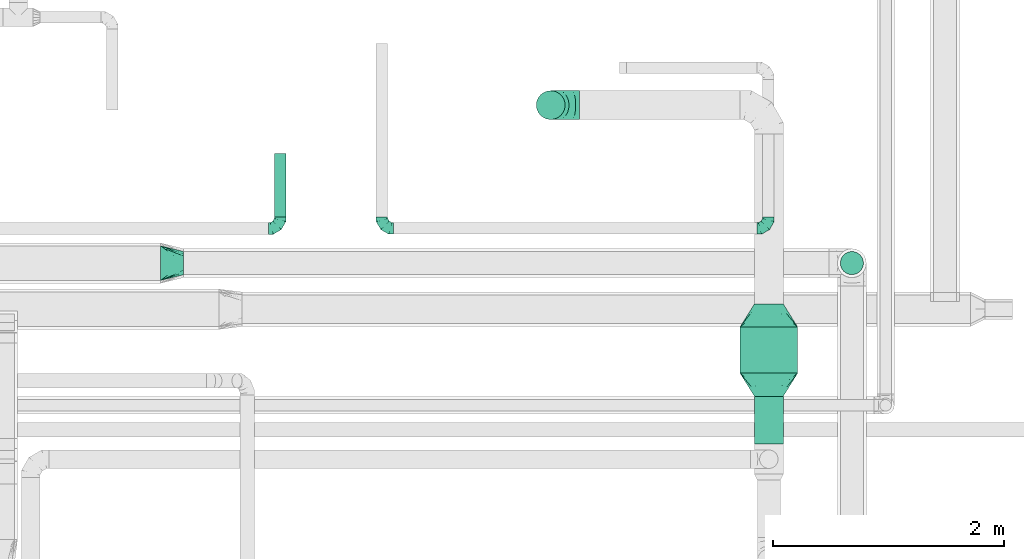
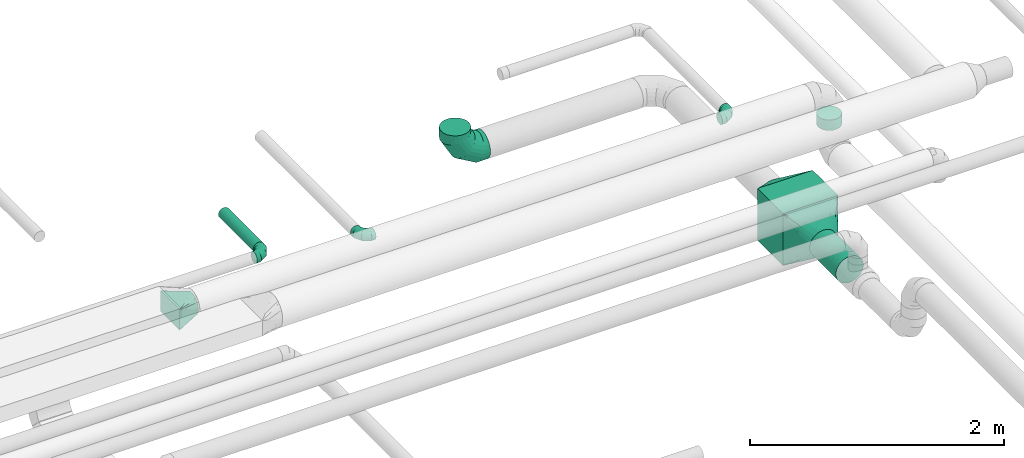
# One storey, part 81 of 92: 7 flow fittings, 4 flow segments.
"""IFC2X3 building model written with IfcOpenShell, lengths in millimetres."""

import ifcopenshell
import ifcopenshell.guid

model = None  # the IFC model being written
_history = None  # IfcOwnerHistory: only IFC2X3 demands one
_inside = {}  # id of a spatial element -> (the spatial element, [elements in it])
_under = {}  # id of a project, library or spatial element -> (it, [spatial elements below it])
_declared = {}  # id of a project -> (the project, [libraries it declares])
_typed = {}  # id of a type object -> (the type object, [elements of that type])
_made_of = {}  # id of a material, layer set ... -> (it, [elements and type objects made of it])


def new_model(schema):
    """Start an empty IFC model of exactly this schema.

    Asked for "IFC4X3", IfcOpenShell would pick the latest addendum, in which some entities
    have other attributes; the version numbers below select the first issue.
    IFC2X3 requires an IfcOwnerHistory on every rooted entity: one is made here for all.
    """
    global model, _history
    if schema == "IFC4X3":
        model = ifcopenshell.file(schema_version=(4, 3, 0, 0))
    else:
        model = ifcopenshell.file(schema=schema)
    _inside.clear()
    _under.clear()
    _declared.clear()
    _typed.clear()
    _made_of.clear()
    _history = None
    if model.schema == "IFC2X3":
        org = make("IfcOrganization", Name="unknown")
        user = make(
            "IfcPersonAndOrganization",
            ThePerson=make("IfcPerson", FamilyName="unknown"),
            TheOrganization=org,
        )
        app = make(
            "IfcApplication",
            ApplicationDeveloper=org,
            Version="unknown",
            ApplicationFullName="unknown",
            ApplicationIdentifier="unknown",
        )
        _history = make(
            "IfcOwnerHistory",
            OwningUser=user,
            OwningApplication=app,
            ChangeAction="ADDED",
            CreationDate=0,
        )
    return model


def make(cls, **values):
    """One entity of the class cls with the attributes given. An attribute that is None is left unset."""
    return model.create_entity(
        cls, **{name: value for name, value in values.items() if value is not None}
    )


def entity(cls, *values):
    """Any entity or typed value of the class cls, its attributes in the order of the schema. None: left unset."""
    e = model.create_entity(cls)
    for i, value in enumerate(values):
        if value is not None:
            e[i] = value
    return e


def rooted(cls, **values):
    """An entity with a GlobalId (a new one), such as an element, a storey or a relation."""
    return make(cls, GlobalId=ifcopenshell.guid.new(), OwnerHistory=_history, **values)


def si_unit(unit_type, name, prefix=None):
    """IfcSIUnit, for example si_unit("LENGTHUNIT", "METRE", prefix="MILLI")."""
    return make("IfcSIUnit", UnitType=unit_type, Prefix=prefix, Name=name)


def converted_unit(unit_type, name, factor, base, dimensions=None, offset=None):
    """IfcConversionBasedUnit, such as the inch: factor (a typed value) times the base unit."""
    return make(
        "IfcConversionBasedUnit"
        if offset is None
        else "IfcConversionBasedUnitWithOffset",
        ConversionOffset=offset,
        Dimensions=None
        if dimensions is None
        else entity("IfcDimensionalExponents", *dimensions),
        UnitType=unit_type,
        Name=name,
        ConversionFactor=make(
            "IfcMeasureWithUnit", ValueComponent=factor, UnitComponent=base
        ),
    )


def derived_unit(unit_type, elements):
    """IfcDerivedUnit: a product of units, each with its exponent."""
    return make(
        "IfcDerivedUnit",
        Elements=[
            make("IfcDerivedUnitElement", Unit=unit, Exponent=power)
            for unit, power in elements
        ],
        UnitType=unit_type,
    )


def assignment(units):
    """IfcUnitAssignment: the units of a project."""
    return None if units is None else make("IfcUnitAssignment", Units=units)


def point(xyz):
    """IfcCartesianPoint."""
    return None if xyz is None else make("IfcCartesianPoint", Coordinates=xyz)


def direction(xyz):
    """IfcDirection."""
    return None if xyz is None else make("IfcDirection", DirectionRatios=xyz)


def frame(location, z_axis=None, x_axis=None):
    """IfcAxis2Placement3D, a coordinate frame: its origin and axes. An axis left out is left unset."""
    return make(
        "IfcAxis2Placement3D",
        Location=point(location),
        Axis=direction(z_axis),
        RefDirection=direction(x_axis),
    )


def frame_2d(location, x_axis=None):
    """IfcAxis2Placement2D, a coordinate frame in the plane: its origin and x axis."""
    return make(
        "IfcAxis2Placement2D", Location=point(location), RefDirection=direction(x_axis)
    )


def origin():
    """The frame at (0, 0, 0) with its axes left unset."""
    return frame((0.0, 0.0, 0.0))


def origin_2d_with_axis():
    """The frame at (0, 0) in the plane with the x axis (1, 0) written out."""
    return frame_2d((0.0, 0.0), x_axis=(1.0, 0.0))


def place(relative_to, where):
    """IfcLocalPlacement: puts the frame where relative to a parent placement (None: the world)."""
    return make(
        "IfcLocalPlacement", PlacementRelTo=relative_to, RelativePlacement=where
    )


def context(
    kind, dimensions, precision=None, world=None, true_north=None, identifier=None
):
    """IfcGeometricRepresentationContext, for example the 3D "Model" context."""
    return make(
        "IfcGeometricRepresentationContext",
        ContextIdentifier=identifier,
        ContextType=kind,
        CoordinateSpaceDimension=dimensions,
        Precision=precision,
        WorldCoordinateSystem=world,
        TrueNorth=true_north,
    )


def subcontext(parent, identifier, kind, view, scale=None):
    """IfcGeometricRepresentationSubContext, for example "Body" below "Model"."""
    return make(
        "IfcGeometricRepresentationSubContext",
        ContextIdentifier=identifier,
        ContextType=kind,
        ParentContext=parent,
        TargetScale=scale,
        TargetView=view,
    )


def project(units=None, contexts=None):
    """IfcProject with its units and contexts."""
    return rooted(
        "IfcProject",
        Name="project",
        RepresentationContexts=contexts,
        UnitsInContext=assignment(units),
    )


def spatial(cls, under=None, at=None, **own):
    """A site, building, storey or space (cls), placed at a placement, below another one or the project."""
    s = rooted(cls, ObjectPlacement=at, **own)
    if under is not None:
        _under.setdefault(under.id(), (under, []))[1].append(s)
    return s


def profile(cls, at=None, kind="AREA", **sizes):
    """A parametric profile (cls). Its sizes go by their IFC names, for example OverallWidth=200.0."""
    return make(cls, ProfileType=kind, Position=at, **sizes)


def rectangle(**sizes):
    """IfcRectangleProfileDef."""
    return profile("IfcRectangleProfileDef", **sizes)


def circle(**sizes):
    """IfcCircleProfileDef."""
    return profile("IfcCircleProfileDef", **sizes)


def extrude(swept, where, along, depth):
    """IfcExtrudedAreaSolid: the profile swept, set in the frame where, extruded along a direction by depth."""
    return make(
        "IfcExtrudedAreaSolid",
        SweptArea=swept,
        Position=where,
        ExtrudedDirection=direction(along),
        Depth=depth,
    )


def faces_of(points, faces, orient=None, outer=None):
    """IfcFace entities. A face is a list of loops; a loop is a list of indices into points, from 0.

    orient and outer hold one flag for each loop. By default every Orientation is true, the
    first loop of a face is its IfcFaceOuterBound and the others are IfcFaceBound.
    """
    made = []
    for i, loops in enumerate(faces):
        bounds = []
        for j, loop in enumerate(loops):
            is_outer = j == 0 if outer is None else outer[i][j]
            bounds.append(
                make(
                    "IfcFaceOuterBound" if is_outer else "IfcFaceBound",
                    Bound=make("IfcPolyLoop", Polygon=[points[k] for k in loop]),
                    Orientation=True if orient is None else orient[i][j],
                )
            )
        made.append(make("IfcFace", Bounds=bounds))
    return made


def faceted_brep(points, faces, orient=None, outer=None, voids=None):
    """IfcFacetedBrep: a solid bounded by flat faces; with voids (closed shells), ...WithVoids."""
    shared = [point(p) for p in points]
    hull = make("IfcClosedShell", CfsFaces=faces_of(shared, faces, orient, outer))
    if voids is None:
        return make("IfcFacetedBrep", Outer=hull)
    return make(
        "IfcFacetedBrepWithVoids",
        Outer=hull,
        Voids=[
            make(cls, CfsFaces=faces_of(shared, fs, o, b)) for cls, fs, o, b in voids
        ],
    )


def shape(context_of_items, identifier, shape_type, items):
    """IfcShapeRepresentation: the items that make up one representation, for example the "Body"."""
    return make(
        "IfcShapeRepresentation",
        ContextOfItems=context_of_items,
        RepresentationIdentifier=identifier,
        RepresentationType=shape_type,
        Items=items,
    )


def source(mapping_origin, context_of_items, identifier, shape_type, items):
    """IfcRepresentationMap: a shape defined once, which mapped items show again and again."""
    return make(
        "IfcRepresentationMap",
        MappingOrigin=mapping_origin,
        MappedRepresentation=shape(context_of_items, identifier, shape_type, items),
    )


def transform(
    local_origin,
    x_axis=None,
    y_axis=None,
    z_axis=None,
    scale=None,
    scale2=None,
    scale3=None,
    uniform=True,
):
    """IfcCartesianTransformationOperator3D, or its non-uniform kind. x_axis, y_axis, z_axis: its Axis1, 2, 3."""
    if uniform:
        return make(
            "IfcCartesianTransformationOperator3D",
            Axis1=direction(x_axis),
            Axis2=direction(y_axis),
            LocalOrigin=point(local_origin),
            Scale=scale,
            Axis3=direction(z_axis),
        )
    return make(
        "IfcCartesianTransformationOperator3DnonUniform",
        Axis1=direction(x_axis),
        Axis2=direction(y_axis),
        LocalOrigin=point(local_origin),
        Scale=scale,
        Axis3=direction(z_axis),
        Scale2=scale2,
        Scale3=scale3,
    )


def mapped(mapping_source, mapping_target):
    """IfcMappedItem: shows the shape of a source again, moved by a transform."""
    return make(
        "IfcMappedItem", MappingSource=mapping_source, MappingTarget=mapping_target
    )


def material(Name=None, Category=None):
    """IfcMaterial."""
    return make("IfcMaterial", Name=Name, Category=Category)


def made_of(thing, what):
    """Note that an element or type object is made of a material, layer set ...; save() writes the relation."""
    if what is not None:
        _made_of.setdefault(what.id(), (what, []))[1].append(thing)
    return thing


def type_object(cls, material=None, **own):
    """A type object (cls), such as IfcWallType, which elements share."""
    return made_of(rooted(cls, **own), material)


def type_shapes(of_type, sources):
    """Give a type object the sources (RepresentationMaps) that its elements show as mapped items."""
    of_type.RepresentationMaps = sources


def element(
    cls,
    number,
    at=None,
    inside=None,
    cuts=None,
    type_object=None,
    material=None,
    context=None,
    identifier="Body",
    shape_type=None,
    held_by="IfcProductDefinitionShape",
    body=None,
    shapes=None,
    **own,
):
    """One element of the class cls, such as IfcWall. Its Tag is "e" and its number.

    at: its placement. inside: the storey or other place that contains it. cuts: it is an
    opening in that element (IfcRelVoidsElement). A single representation is given by context,
    identifier, shape_type and body (its items); several are given by shapes. held_by: the class
    of the entity that holds the representations. save() writes the other relations.
    """
    e = rooted(cls, Tag="e%d" % number, ObjectPlacement=at, **own)
    if body is not None:
        shapes = [shape(context, identifier, shape_type, body)]
    if shapes is not None:
        e.Representation = make(held_by, Representations=shapes)
    if inside is not None:
        _inside.setdefault(inside.id(), (inside, []))[1].append(e)
    if cuts is not None:
        rooted(
            "IfcRelVoidsElement", RelatingBuildingElement=cuts, RelatedOpeningElement=e
        )
    if type_object is not None:
        _typed.setdefault(type_object.id(), (type_object, []))[1].append(e)
    return made_of(e, material)


def aggregate(whole, parts):
    """IfcRelAggregates: a whole, such as a stair, and the parts it consists of."""
    return rooted("IfcRelAggregates", RelatingObject=whole, RelatedObjects=parts)


def save(model, path):
    """Write the relations noted so far, then the file.

    IfcRelAggregates (storeys below a building ...), IfcRelContainedInSpatialStructure (elements
    in a storey), IfcRelDefinesByType, IfcRelAssociatesMaterial and IfcRelDeclares: one each for
    every whole, place, type object, material and project.
    """
    for whole, parts in _under.values():
        aggregate(whole, parts)
    for where, things in _inside.values():
        rooted(
            "IfcRelContainedInSpatialStructure",
            RelatedElements=things,
            RelatingStructure=where,
        )
    for kind, things in _typed.values():
        rooted("IfcRelDefinesByType", RelatedObjects=things, RelatingType=kind)
    for what, things in _made_of.values():
        rooted("IfcRelAssociatesMaterial", RelatedObjects=things, RelatingMaterial=what)
    for by, libraries in _declared.values():
        rooted("IfcRelDeclares", RelatingContext=by, RelatedDefinitions=libraries)
    model.write(path)


model = new_model("IFC2X3")

# Units and contexts
model_context = context("Model", 3, precision=0.01, world=origin(), true_north=direction((6.12303176911189e-17, 1.0)))
body_context = subcontext(model_context, "Body", "Model", "MODEL_VIEW")
ifc_project = project(units=[si_unit("LENGTHUNIT", "METRE", prefix="MILLI"), si_unit("AREAUNIT", "SQUARE_METRE"), si_unit("VOLUMEUNIT", "CUBIC_METRE"), converted_unit("PLANEANGLEUNIT", "DEGREE", entity("IfcRatioMeasure", 0.0174532925199433), si_unit("PLANEANGLEUNIT", "RADIAN"), dimensions=[0, 0, 0, 0, 0, 0, 0]), si_unit("MASSUNIT", "GRAM", prefix="KILO"), derived_unit("MASSDENSITYUNIT", [(si_unit("MASSUNIT", "GRAM", prefix="KILO"), 1), (si_unit("LENGTHUNIT", "METRE"), -3)]), derived_unit("MOMENTOFINERTIAUNIT", [(si_unit("LENGTHUNIT", "METRE"), 4)]), si_unit("TIMEUNIT", "SECOND"), si_unit("FREQUENCYUNIT", "HERTZ"), si_unit("THERMODYNAMICTEMPERATUREUNIT", "DEGREE_CELSIUS"), derived_unit("THERMALTRANSMITTANCEUNIT", [(si_unit("MASSUNIT", "GRAM", prefix="KILO"), 1), (si_unit("THERMODYNAMICTEMPERATUREUNIT", "KELVIN"), -1), (si_unit("TIMEUNIT", "SECOND"), -3)]), derived_unit("VOLUMETRICFLOWRATEUNIT", [(si_unit("LENGTHUNIT", "METRE"), 3), (si_unit("TIMEUNIT", "SECOND"), -1)]), derived_unit("MASSFLOWRATEUNIT", [(si_unit("MASSUNIT", "GRAM", prefix="KILO"), 1), (si_unit("TIMEUNIT", "SECOND"), -1)]), derived_unit("ROTATIONALFREQUENCYUNIT", [(si_unit("TIMEUNIT", "SECOND"), -1)]), si_unit("ELECTRICCURRENTUNIT", "AMPERE"), si_unit("ELECTRICVOLTAGEUNIT", "VOLT"), si_unit("POWERUNIT", "WATT"), si_unit("FORCEUNIT", "NEWTON", prefix="KILO"), si_unit("ILLUMINANCEUNIT", "LUX"), si_unit("LUMINOUSFLUXUNIT", "LUMEN"), si_unit("LUMINOUSINTENSITYUNIT", "CANDELA"), derived_unit("USERDEFINED", [(si_unit("MASSUNIT", "GRAM", prefix="KILO"), -1), (si_unit("LENGTHUNIT", "METRE"), -2), (si_unit("TIMEUNIT", "SECOND"), 3), (si_unit("LUMINOUSFLUXUNIT", "LUMEN"), 1)]), derived_unit("LINEARVELOCITYUNIT", [(si_unit("LENGTHUNIT", "METRE"), 1), (si_unit("TIMEUNIT", "SECOND"), -1)]), si_unit("PRESSUREUNIT", "PASCAL"), derived_unit("USERDEFINED", [(si_unit("LENGTHUNIT", "METRE"), -2), (si_unit("MASSUNIT", "GRAM", prefix="KILO"), 1), (si_unit("TIMEUNIT", "SECOND"), -2)]), derived_unit("LINEARFORCEUNIT", [(si_unit("MASSUNIT", "GRAM", prefix="KILO"), 1), (si_unit("LENGTHUNIT", "METRE"), 1), (si_unit("TIMEUNIT", "SECOND"), -2), (si_unit("LENGTHUNIT", "METRE"), -1)]), derived_unit("PLANARFORCEUNIT", [(si_unit("MASSUNIT", "GRAM", prefix="KILO"), 1), (si_unit("LENGTHUNIT", "METRE"), 1), (si_unit("TIMEUNIT", "SECOND"), -2), (si_unit("LENGTHUNIT", "METRE"), -2)])], contexts=[model_context])

# Site, building, storey
site_placement = place(None, origin())
site = spatial("IfcSite", under=ifc_project, at=site_placement, CompositionType="ELEMENT")
building_placement = place(site_placement, origin())
building = spatial("IfcBuilding", under=site, at=building_placement, CompositionType="ELEMENT")
storey_placement = place(building_placement, frame((0.0, 0.0, 4200.0)))
storey = spatial("IfcBuildingStorey", under=building, at=storey_placement, CompositionType="ELEMENT", Elevation=4200.0)

# Flow segments
duct_segment_type_1 = type_object("IfcDuctSegmentType", PredefinedType="NOTDEFINED")
flow_segment_1_placement = place(storey_placement, frame((69680.58, 9021.28, 2550.0)))
element("IfcFlowSegment", 1, at=flow_segment_1_placement, inside=storey, type_object=duct_segment_type_1, context=body_context, shape_type="SweptSolid", body=[
    extrude(rectangle(XDim=400.0, YDim=499.999999999999, at=origin_2d_with_axis()), frame((250.0, 200.0, 0.0), z_axis=(0.0, 0.0, 1.0), x_axis=(0.0, -1.0, 0.0)), (0.0, 0.0, 1.0), 500.000000000001),
])
duct_segment_type_2 = type_object("IfcDuctSegmentType", PredefinedType="NOTDEFINED")
flow_segment_2_placement = place(storey_placement, frame((69803.98, 8405.8, 2673.4)))
element("IfcFlowSegment", 2, at=flow_segment_2_placement, inside=storey, type_object=duct_segment_type_2, context=body_context, shape_type="SweptSolid", body=[
    extrude(circle(Radius=125.0, at=origin_2d_with_axis()), frame((126.6, 0.0, 126.6), z_axis=(0.0, 1.0, 0.0), x_axis=(-1.0, 0.0, 0.0)), (0.0, 0.0, 1.0), 415.474769663804),
])
flow_segment_3_placement = place(storey_placement, frame((70548.47, 9873.33, 3000.0)))
element("IfcFlowSegment", 3, at=flow_segment_3_placement, inside=storey, type_object=duct_segment_type_2, context=body_context, shape_type="SweptSolid", body=[
    extrude(circle(Radius=100.0, at=origin_2d_with_axis()), frame((101.6, 101.6, 0.0), z_axis=(0.0, 0.0, 1.0), x_axis=(0.0, 1.0, 0.0)), (0.0, 0.0, 1.0), 100.00000000002),
])
duct_segment_type_3 = type_object("IfcDuctSegmentType", PredefinedType="NOTDEFINED")
flow_segment_4_placement = place(storey_placement, frame((65644.8, 10374.95, 3248.29)))
element("IfcFlowSegment", 4, at=flow_segment_4_placement, inside=storey, type_object=duct_segment_type_3, context=body_context, shape_type="SweptSolid", body=[
    extrude(circle(Radius=50.0, at=origin_2d_with_axis()), frame((51.6, 0.0, 51.6), z_axis=(0.0, 1.0, 0.0), x_axis=(1.0, 0.0, 0.0)), (0.0, 0.0, 1.0), 549.200000000007),
])

# Flow fittings
ifc_material = material()
duct_fitting_type_1 = type_object("IfcDuctFittingType", PredefinedType="NOTDEFINED", material=ifc_material)
shared_shape_1 = source(origin(), body_context, "Body", "Brep", [
    faceted_brep([(-100.0, 0.0, -50.0), (-100.0, -12.94, -48.3), (-100.0, -25.0, -43.3), (-100.0, -35.36, -35.36), (-100.0, -43.3, -25.0), (-100.0, -48.3, -12.94), (-100.0, -50.0, 0.0), (-100.0, -48.3, 12.94), (-100.0, -43.3, 25.0), (-100.0, -35.36, 35.36), (-100.0, -25.0, 43.3), (-100.0, -12.94, 48.3), (-100.0, 0.0, 50.0), (-100.0, 12.94, 48.3), (-100.0, 25.0, 43.3), (-100.0, 35.36, 35.36), (-100.0, 43.3, 25.0), (-100.0, 48.3, 12.94), (-100.0, 50.0, 0.0), (-100.0, 48.3, -12.94), (-100.0, 43.3, -25.0), (-100.0, 35.36, -35.36), (-100.0, 25.0, -43.3), (-100.0, 12.94, -48.3), (-76.67, 12.94, 48.3), (-79.9, 25.0, 43.3), (-73.21, 0.0, 50.0), (-82.68, 35.36, 35.36), (-86.15, 48.3, 12.94), (-86.6, 50.0, 0.0), (-84.81, 43.3, 25.0), (-84.81, 43.3, -25.0), (-82.68, 35.36, -35.36), (-86.15, 48.3, -12.94), (-76.67, 12.94, -48.3), (-73.21, 0.0, -50.0), (-79.9, 25.0, -43.3), (-69.74, -12.94, -48.3), (-66.51, -25.0, -43.3), (-63.73, -35.36, -35.36), (-61.6, -43.3, -25.0), (-60.26, -48.3, -12.94), (-59.81, -50.0, 0.0), (-60.26, -48.3, 12.94), (-61.6, -43.3, 25.0), (-63.73, -35.36, 35.36), (-66.51, -25.0, 43.3), (-69.74, -12.94, 48.3), (-36.27, 36.27, 48.3), (-45.1, 45.1, 43.3), (-26.79, 26.79, 50.0), (-52.68, 52.68, 35.36), (-58.49, 58.49, 25.0), (-62.15, 62.15, 12.94), (-63.4, 63.4, 0.0), (-62.15, 62.15, -12.94), (-58.49, 58.49, -25.0), (-52.68, 52.68, -35.36), (-36.27, 36.27, -48.3), (-26.79, 26.79, -50.0), (-45.1, 45.1, -43.3), (-17.32, 17.32, -48.3), (-8.49, 8.49, -43.3), (-0.91, 0.91, -35.36), (4.9, -4.9, -25.0), (8.56, -8.56, -12.94), (9.81, -9.81, 0.0), (8.56, -8.56, 12.94), (4.9, -4.9, 25.0), (-0.91, 0.91, 35.36), (-8.49, 8.49, 43.3), (-17.32, 17.32, 48.3), (-12.94, 76.67, 48.3), (-25.0, 79.9, 43.3), (0.0, 73.21, 50.0), (-35.36, 82.68, 35.36), (-43.3, 84.81, 25.0), (-48.3, 86.15, 12.94), (-50.0, 86.6, 0.0), (-48.3, 86.15, -12.94), (-43.3, 84.81, -25.0), (-35.36, 82.68, -35.36), (-12.94, 76.67, -48.3), (0.0, 73.21, -50.0), (-25.0, 79.9, -43.3), (12.94, 69.74, -48.3), (25.0, 66.51, -43.3), (35.36, 63.73, -35.36), (43.3, 61.6, -25.0), (48.3, 60.26, -12.94), (50.0, 59.81, 0.0), (48.3, 60.26, 12.94), (43.3, 61.6, 25.0), (35.36, 63.73, 35.36), (25.0, 66.51, 43.3), (12.94, 69.74, 48.3), (-12.94, 100.0, -48.3), (-25.0, 100.0, -43.3), (-35.36, 100.0, -35.36), (-43.3, 100.0, -25.0), (-48.3, 100.0, -12.94), (-50.0, 100.0, 0.0), (-48.3, 100.0, 12.94), (-43.3, 100.0, 25.0), (-35.36, 100.0, 35.36), (-25.0, 100.0, 43.3), (-12.94, 100.0, 48.3), (0.0, 100.0, 50.0), (12.94, 100.0, 48.3), (25.0, 100.0, 43.3), (35.36, 100.0, 35.36), (43.3, 100.0, 25.0), (48.3, 100.0, 12.94), (50.0, 100.0, 0.0), (48.3, 100.0, -12.94), (43.3, 100.0, -25.0), (35.36, 100.0, -35.36), (25.0, 100.0, -43.3), (12.94, 100.0, -48.3), (0.0, 100.0, -50.0)], [[[0, 1, 2, 3, 4, 5, 6, 7, 8, 9, 10, 11, 12, 13, 14, 15, 16, 17, 18, 19, 20, 21, 22, 23]], [[24, 25, 14, 13]], [[26, 24, 13, 12]], [[14, 25, 27, 15]], [[28, 29, 18, 17]], [[30, 28, 17, 16]], [[15, 27, 30, 16]], [[20, 31, 32, 21]], [[33, 31, 20, 19]], [[18, 29, 33, 19]], [[34, 35, 0, 23]], [[36, 34, 23, 22]], [[32, 36, 22, 21]], [[2, 1, 37, 38]], [[3, 2, 38, 39]], [[0, 35, 37, 1]], [[5, 4, 40, 41]], [[6, 5, 41, 42]], [[3, 39, 40, 4]], [[6, 42, 43, 7]], [[7, 43, 44, 8]], [[8, 44, 45, 9]], [[10, 46, 47, 11]], [[11, 47, 26, 12]], [[10, 9, 45, 46]], [[48, 49, 25, 24]], [[50, 48, 24, 26]], [[27, 25, 49, 51]], [[52, 53, 28, 30]], [[51, 52, 30, 27]], [[29, 28, 53, 54]], [[55, 56, 31, 33]], [[54, 55, 33, 29]], [[57, 32, 31, 56]], [[58, 59, 35, 34]], [[60, 58, 34, 36]], [[57, 60, 36, 32]], [[37, 35, 59, 61]], [[38, 37, 61, 62]], [[39, 38, 62, 63]], [[41, 40, 64, 65]], [[42, 41, 65, 66]], [[63, 64, 40, 39]], [[43, 42, 66, 67]], [[44, 43, 67, 68]], [[68, 69, 45, 44]], [[46, 45, 69, 70]], [[47, 46, 70, 71]], [[26, 47, 71, 50]], [[72, 73, 49, 48]], [[74, 72, 48, 50]], [[51, 49, 73, 75]], [[76, 77, 53, 52]], [[75, 76, 52, 51]], [[54, 53, 77, 78]], [[79, 80, 56, 55]], [[78, 79, 55, 54]], [[81, 57, 56, 80]], [[82, 83, 59, 58]], [[84, 82, 58, 60]], [[81, 84, 60, 57]], [[61, 59, 83, 85]], [[62, 61, 85, 86]], [[63, 62, 86, 87]], [[65, 64, 88, 89]], [[66, 65, 89, 90]], [[87, 88, 64, 63]], [[67, 66, 90, 91]], [[68, 67, 91, 92]], [[92, 93, 69, 68]], [[70, 69, 93, 94]], [[71, 70, 94, 95]], [[50, 71, 95, 74]], [[96, 97, 98, 99, 100, 101, 102, 103, 104, 105, 106, 107, 108, 109, 110, 111, 112, 113, 114, 115, 116, 117, 118, 119]], [[72, 74, 107, 106]], [[73, 72, 106, 105]], [[75, 73, 105, 104]], [[77, 76, 103, 102]], [[78, 77, 102, 101]], [[75, 104, 103, 76]], [[78, 101, 100, 79]], [[79, 100, 99, 80]], [[80, 99, 98, 81]], [[96, 119, 83, 82]], [[97, 96, 82, 84]], [[84, 81, 98, 97]], [[83, 119, 118, 85]], [[85, 118, 117, 86]], [[86, 117, 116, 87]], [[88, 115, 114, 89]], [[89, 114, 113, 90]], [[87, 116, 115, 88]], [[91, 90, 113, 112]], [[92, 91, 112, 111]], [[93, 92, 111, 110]], [[95, 94, 109, 108]], [[74, 95, 108, 107]], [[110, 109, 94, 93]]]),
])
type_shapes(duct_fitting_type_1, [shared_shape_1])
flow_fitting_1_placement = place(storey_placement, frame((69927.09, 10274.97, 3150.0)))
element("IfcFlowFitting", 5, at=flow_fitting_1_placement, inside=storey, type_object=duct_fitting_type_1, material=ifc_material, context=body_context, shape_type="MappedRepresentation", body=[
    mapped(shared_shape_1, transform((0.0, 0.0, 0.0), scale=1.0)),
])
flow_fitting_2_placement = place(storey_placement, frame((66578.56, 10274.97, 3150.0), z_axis=(0.0, 0.0, 1.0), x_axis=(0.0, -1.0, 0.0)))
element("IfcFlowFitting", 6, at=flow_fitting_2_placement, inside=storey, type_object=duct_fitting_type_1, material=ifc_material, context=body_context, shape_type="MappedRepresentation", body=[
    mapped(shared_shape_1, transform((0.0, 0.0, 0.0), scale=1.0)),
])
flow_fitting_3_placement = place(storey_placement, frame((65696.39, 10274.95, 3299.88)))
element("IfcFlowFitting", 7, at=flow_fitting_3_placement, inside=storey, type_object=duct_fitting_type_1, material=ifc_material, context=body_context, shape_type="MappedRepresentation", body=[
    mapped(shared_shape_1, transform((0.0, 0.0, 0.0), scale=1.0)),
])
duct_fitting_type_2 = type_object("IfcDuctFittingType", PredefinedType="NOTDEFINED", material=ifc_material)
shared_shape_2 = source(origin(), body_context, "Body", "Brep", [
    faceted_brep([(-250.0, 0.0, -125.0), (-250.0, -32.35, -120.74), (-250.0, -62.5, -108.25), (-250.0, -88.39, -88.39), (-250.0, -108.25, -62.5), (-250.0, -120.74, -32.35), (-250.0, -125.0, 0.0), (-250.0, -120.74, 32.35), (-250.0, -108.25, 62.5), (-250.0, -88.39, 88.39), (-250.0, -62.5, 108.25), (-250.0, -32.35, 120.74), (-250.0, 0.0, 125.0), (-250.0, 32.35, 120.74), (-250.0, 62.5, 108.25), (-250.0, 88.39, 88.39), (-250.0, 108.25, 62.5), (-250.0, 120.74, 32.35), (-250.0, 125.0, 0.0), (-250.0, 120.74, -32.35), (-250.0, 108.25, -62.5), (-250.0, 88.39, -88.39), (-250.0, 62.5, -108.25), (-250.0, 32.35, -120.74), (-191.68, 32.35, 120.74), (-199.76, 62.5, 108.25), (-183.01, 0.0, 125.0), (-206.7, 88.39, 88.39), (-215.37, 120.74, 32.35), (-216.51, 125.0, 0.0), (-212.02, 108.25, 62.5), (-212.02, 108.25, -62.5), (-206.7, 88.39, -88.39), (-215.37, 120.74, -32.35), (-191.68, 32.35, -120.74), (-183.01, 0.0, -125.0), (-199.76, 62.5, -108.25), (-174.34, -32.35, -120.74), (-166.27, -62.5, -108.25), (-159.33, -88.39, -88.39), (-154.01, -108.25, -62.5), (-150.66, -120.74, -32.35), (-149.52, -125.0, 0.0), (-150.66, -120.74, 32.35), (-154.01, -108.25, 62.5), (-159.33, -88.39, 88.39), (-166.27, -62.5, 108.25), (-174.34, -32.35, 120.74), (-90.67, 90.67, 120.74), (-112.74, 112.74, 108.25), (-66.99, 66.99, 125.0), (-131.69, 131.69, 88.39), (-146.23, 146.23, 62.5), (-155.38, 155.38, 32.35), (-158.49, 158.49, 0.0), (-155.38, 155.38, -32.35), (-146.23, 146.23, -62.5), (-131.69, 131.69, -88.39), (-90.67, 90.67, -120.74), (-66.99, 66.99, -125.0), (-112.74, 112.74, -108.25), (-43.3, 43.3, -120.74), (-21.23, 21.23, -108.25), (-2.28, 2.28, -88.39), (12.26, -12.26, -62.5), (21.4, -21.4, -32.35), (24.52, -24.52, 0.0), (21.4, -21.4, 32.35), (12.26, -12.26, 62.5), (-2.28, 2.28, 88.39), (-21.23, 21.23, 108.25), (-43.3, 43.3, 120.74), (-32.35, 191.68, 120.74), (-62.5, 199.76, 108.25), (0.0, 183.01, 125.0), (-88.39, 206.7, 88.39), (-108.25, 212.02, 62.5), (-120.74, 215.37, 32.35), (-125.0, 216.51, 0.0), (-120.74, 215.37, -32.35), (-108.25, 212.02, -62.5), (-88.39, 206.7, -88.39), (-32.35, 191.68, -120.74), (0.0, 183.01, -125.0), (-62.5, 199.76, -108.25), (32.35, 174.34, -120.74), (62.5, 166.27, -108.25), (88.39, 159.33, -88.39), (108.25, 154.01, -62.5), (120.74, 150.66, -32.35), (125.0, 149.52, 0.0), (120.74, 150.66, 32.35), (108.25, 154.01, 62.5), (88.39, 159.33, 88.39), (62.5, 166.27, 108.25), (32.35, 174.34, 120.74), (-32.35, 250.0, -120.74), (-62.5, 250.0, -108.25), (-88.39, 250.0, -88.39), (-108.25, 250.0, -62.5), (-120.74, 250.0, -32.35), (-125.0, 250.0, 0.0), (-120.74, 250.0, 32.35), (-108.25, 250.0, 62.5), (-88.39, 250.0, 88.39), (-62.5, 250.0, 108.25), (-32.35, 250.0, 120.74), (0.0, 250.0, 125.0), (32.35, 250.0, 120.74), (62.5, 250.0, 108.25), (88.39, 250.0, 88.39), (108.25, 250.0, 62.5), (120.74, 250.0, 32.35), (125.0, 250.0, 0.0), (120.74, 250.0, -32.35), (108.25, 250.0, -62.5), (88.39, 250.0, -88.39), (62.5, 250.0, -108.25), (32.35, 250.0, -120.74), (0.0, 250.0, -125.0)], [[[0, 1, 2, 3, 4, 5, 6, 7, 8, 9, 10, 11, 12, 13, 14, 15, 16, 17, 18, 19, 20, 21, 22, 23]], [[24, 25, 14, 13]], [[26, 24, 13, 12]], [[14, 25, 27, 15]], [[28, 29, 18, 17]], [[30, 28, 17, 16]], [[15, 27, 30, 16]], [[20, 31, 32, 21]], [[33, 31, 20, 19]], [[18, 29, 33, 19]], [[34, 35, 0, 23]], [[36, 34, 23, 22]], [[21, 32, 36, 22]], [[1, 0, 35, 37]], [[2, 1, 37, 38]], [[38, 39, 3, 2]], [[5, 4, 40, 41]], [[6, 5, 41, 42]], [[39, 40, 4, 3]], [[6, 42, 43, 7]], [[7, 43, 44, 8]], [[8, 44, 45, 9]], [[9, 45, 46, 10]], [[10, 46, 47, 11]], [[26, 12, 11, 47]], [[48, 49, 25, 24]], [[50, 48, 24, 26]], [[27, 25, 49, 51]], [[52, 53, 28, 30]], [[51, 52, 30, 27]], [[29, 28, 53, 54]], [[55, 56, 31, 33]], [[54, 55, 33, 29]], [[32, 31, 56, 57]], [[58, 59, 35, 34]], [[60, 58, 34, 36]], [[57, 60, 36, 32]], [[37, 35, 59, 61]], [[38, 37, 61, 62]], [[39, 38, 62, 63]], [[41, 40, 64, 65]], [[42, 41, 65, 66]], [[63, 64, 40, 39]], [[43, 42, 66, 67]], [[44, 43, 67, 68]], [[68, 69, 45, 44]], [[46, 45, 69, 70]], [[47, 46, 70, 71]], [[26, 47, 71, 50]], [[72, 73, 49, 48]], [[74, 72, 48, 50]], [[51, 49, 73, 75]], [[76, 77, 53, 52]], [[75, 76, 52, 51]], [[54, 53, 77, 78]], [[79, 80, 56, 55]], [[78, 79, 55, 54]], [[57, 56, 80, 81]], [[82, 83, 59, 58]], [[84, 82, 58, 60]], [[81, 84, 60, 57]], [[61, 59, 83, 85]], [[62, 61, 85, 86]], [[63, 62, 86, 87]], [[65, 64, 88, 89]], [[66, 65, 89, 90]], [[87, 88, 64, 63]], [[67, 66, 90, 91]], [[68, 67, 91, 92]], [[92, 93, 69, 68]], [[70, 69, 93, 94]], [[71, 70, 94, 95]], [[50, 71, 95, 74]], [[96, 97, 98, 99, 100, 101, 102, 103, 104, 105, 106, 107, 108, 109, 110, 111, 112, 113, 114, 115, 116, 117, 118, 119]], [[72, 74, 107, 106]], [[73, 72, 106, 105]], [[75, 73, 105, 104]], [[77, 76, 103, 102]], [[78, 77, 102, 101]], [[75, 104, 103, 76]], [[78, 101, 100, 79]], [[79, 100, 99, 80]], [[80, 99, 98, 81]], [[84, 97, 96, 82]], [[82, 96, 119, 83]], [[84, 81, 98, 97]], [[83, 119, 118, 85]], [[85, 118, 117, 86]], [[116, 87, 86, 117]], [[88, 115, 114, 89]], [[89, 114, 113, 90]], [[115, 88, 87, 116]], [[91, 90, 113, 112]], [[92, 91, 112, 111]], [[111, 110, 93, 92]], [[95, 94, 109, 108]], [[74, 95, 108, 107]], [[110, 109, 94, 93]]]),
])
type_shapes(duct_fitting_type_2, [shared_shape_2])
flow_fitting_4_placement = place(storey_placement, frame((68040.58, 11343.71, 2800.0), z_axis=(0.0, 1.0, 0.0), x_axis=(-1.0, 0.0, 0.0)))
element("IfcFlowFitting", 8, at=flow_fitting_4_placement, inside=storey, type_object=duct_fitting_type_2, material=ifc_material, context=body_context, shape_type="MappedRepresentation", body=[
    mapped(shared_shape_2, transform((0.0, 0.0, 0.0), scale=1.0)),
])
duct_fitting_type_3 = type_object("IfcDuctFittingType", PredefinedType="NOTDEFINED", material=ifc_material)
shared_shape_3 = source(origin(), body_context, "Body", "Brep", [
    faceted_brep([(200.0, 73.47, 101.13), (200.0, 56.05, 110.0), (200.0, 38.63, 118.88), (200.0, 23.84, 121.22), (200.0, 11.92, 123.11), (200.0, 5.96, 124.06), (200.0, 0.0, 125.0), (200.0, -5.96, 124.06), (200.0, -11.92, 123.11), (200.0, -23.84, 121.22), (200.0, -38.63, 118.88), (200.0, -56.05, 110.0), (200.0, -73.47, 101.13), (200.0, -87.3, 87.3), (200.0, -101.13, 73.47), (200.0, -110.0, 56.05), (200.0, -118.88, 38.63), (200.0, -121.22, 23.84), (200.0, -123.11, 11.92), (200.0, -124.06, 5.96), (200.0, -125.0, 0.0), (200.0, -124.06, -5.96), (200.0, -123.11, -11.92), (200.0, -121.22, -23.84), (200.0, -118.88, -38.63), (200.0, -110.0, -56.05), (200.0, -101.13, -73.47), (200.0, -87.3, -87.3), (200.0, -73.47, -101.13), (200.0, -56.05, -110.0), (200.0, -38.63, -118.88), (200.0, -23.84, -121.22), (200.0, -11.92, -123.11), (200.0, -5.96, -124.06), (200.0, 0.0, -125.0), (200.0, 5.96, -124.06), (200.0, 11.92, -123.11), (200.0, 23.84, -121.22), (200.0, 38.63, -118.88), (200.0, 56.05, -110.0), (200.0, 73.47, -101.13), (200.0, 87.3, -87.3), (200.0, 101.13, -73.47), (200.0, 110.0, -56.05), (200.0, 118.88, -38.63), (200.0, 121.22, -23.84), (200.0, 123.11, -11.92), (200.0, 124.06, -5.96), (200.0, 125.0, 0.0), (200.0, 124.06, 5.96), (200.0, 123.11, 11.92), (200.0, 121.22, 23.84), (200.0, 118.88, 38.63), (200.0, 110.0, 56.05), (200.0, 101.13, 73.47), (200.0, 87.3, 87.3), (0.0, -250.0, 250.0), (0.0, 250.0, 250.0), (0.0, 250.0, -250.0), (0.0, -250.0, -250.0), (104.11, -119.86, 184.93), (100.0, -166.44, 171.79), (26.03, -217.46, 233.73), (78.09, -152.39, 201.2), (52.06, -184.93, 217.46), (188.01, -14.98, 132.49), (176.03, -29.96, 139.98), (152.06, -59.93, 154.96), (128.09, -89.89, 169.95), (52.06, -217.46, 184.93), (78.09, -201.2, 152.39), (104.11, -184.93, 119.86), (128.09, -169.95, 89.89), (152.06, -154.96, 59.93), (176.03, -139.98, 29.96), (188.01, -132.49, 14.98), (26.03, -233.73, 217.46), (26.03, -233.73, -217.46), (52.06, -217.46, -184.93), (78.09, -201.2, -152.39), (104.11, -184.93, -119.86), (128.09, -169.95, -89.89), (152.06, -154.96, -59.93), (176.03, -139.98, -29.96), (188.01, -132.49, -14.98), (100.0, -171.79, -166.44), (52.06, -184.93, -217.46), (78.09, -152.39, -201.2), (104.11, -119.86, -184.93), (128.09, -89.89, -169.95), (152.06, -59.93, -154.96), (176.03, -29.96, -139.98), (188.01, -14.98, -132.49), (26.03, -217.46, -233.73), (26.03, 217.46, -233.73), (52.06, 184.93, -217.46), (78.09, 152.39, -201.2), (104.11, 119.86, -184.93), (128.09, 89.89, -169.95), (152.06, 59.93, -154.96), (176.03, 29.96, -139.98), (188.01, 14.98, -132.49), (100.0, 166.44, -171.79), (52.06, 217.46, -184.93), (78.09, 201.2, -152.39), (104.11, 184.93, -119.86), (128.09, 169.95, -89.89), (152.06, 154.96, -59.93), (176.03, 139.98, -29.96), (188.01, 132.49, -14.98), (26.03, 233.73, -217.46), (26.03, 233.73, 217.46), (52.06, 217.46, 184.93), (78.09, 201.2, 152.39), (104.11, 184.93, 119.86), (128.09, 169.95, 89.89), (152.06, 154.96, 59.93), (176.03, 139.98, 29.96), (188.01, 132.49, 14.98), (100.0, 171.79, 166.44), (52.06, 184.93, 217.46), (78.09, 152.39, 201.2), (104.11, 119.86, 184.93), (128.09, 89.89, 169.95), (152.06, 59.93, 154.96), (176.03, 29.96, 139.98), (188.01, 14.98, 132.49), (26.03, 217.46, 233.73)], [[[0, 1, 2, 3, 4, 5, 6, 7, 8, 9, 10, 11, 12, 13, 14, 15, 16, 17, 18, 19, 20, 21, 22, 23, 24, 25, 26, 27, 28, 29, 30, 31, 32, 33, 34, 35, 36, 37, 38, 39, 40, 41, 42, 43, 44, 45, 46, 47, 48, 49, 50, 51, 52, 53, 54, 55]], [[56, 57, 58, 59]], [[60, 11, 10]], [[56, 61, 62]], [[11, 60, 63, 64]], [[65, 66, 67, 68, 60, 10, 9, 8, 7, 6]], [[62, 61, 12]], [[15, 69, 70, 71]], [[64, 12, 11]], [[16, 71, 72, 73, 74, 75, 20, 19, 18, 17]], [[14, 76, 69]], [[71, 16, 15]], [[61, 76, 13]], [[12, 64, 62]], [[76, 14, 13]], [[12, 61, 13]], [[61, 56, 76]], [[69, 15, 14]], [[75, 74, 73, 72, 71, 70, 69, 76, 56, 59, 77, 78, 79, 80, 81, 82, 83, 84, 20]], [[80, 25, 24]], [[59, 85, 77]], [[25, 80, 79, 78]], [[84, 83, 82, 81, 80, 24, 23, 22, 21, 20]], [[77, 85, 26]], [[29, 86, 87, 88]], [[78, 26, 25]], [[30, 88, 89, 90, 91, 92, 34, 33, 32, 31]], [[28, 93, 86]], [[88, 30, 29]], [[85, 93, 27]], [[26, 78, 77]], [[93, 28, 27]], [[26, 85, 27]], [[85, 59, 93]], [[86, 29, 28]], [[92, 91, 90, 89, 88, 87, 86, 93, 59, 58, 94, 95, 96, 97, 98, 99, 100, 101, 34]], [[97, 39, 38]], [[58, 102, 94]], [[39, 97, 96, 95]], [[101, 100, 99, 98, 97, 38, 37, 36, 35, 34]], [[94, 102, 40]], [[43, 103, 104, 105]], [[95, 40, 39]], [[44, 105, 106, 107, 108, 109, 48, 47, 46, 45]], [[42, 110, 103]], [[105, 44, 43]], [[102, 110, 41]], [[40, 95, 94]], [[110, 42, 41]], [[40, 102, 41]], [[102, 58, 110]], [[103, 43, 42]], [[58, 57, 111, 112, 113, 114, 115, 116, 117, 118, 48, 109, 108, 107, 106, 105, 104, 103, 110]], [[114, 53, 52]], [[57, 119, 111]], [[53, 114, 113, 112]], [[118, 117, 116, 115, 114, 52, 51, 50, 49, 48]], [[111, 119, 54]], [[1, 120, 121, 122]], [[112, 54, 53]], [[2, 122, 123, 124, 125, 126, 6, 5, 4, 3]], [[0, 127, 120]], [[122, 2, 1]], [[119, 127, 55]], [[54, 112, 111]], [[127, 0, 55]], [[54, 119, 55]], [[119, 57, 127]], [[120, 1, 0]], [[57, 56, 62, 64, 63, 60, 68, 67, 66, 65, 6, 126, 125, 124, 123, 122, 121, 120, 127]]]),
])
type_shapes(duct_fitting_type_3, [shared_shape_3])
for number, where, z_axis, x_axis in (
    (9, (69930.58, 9021.28, 2800.0), (0.0, 0.0, 1.0), (0.0, -1.0, 0.0)),
    (10, (69930.58, 9421.28, 2800.0), (0.0, 0.0, 1.0), (0.0, 1.0, 0.0)),
):
    element("IfcFlowFitting", number, at=place(storey_placement, frame(where, z_axis=z_axis, x_axis=x_axis)), inside=storey, type_object=duct_fitting_type_3, material=ifc_material, context=body_context, shape_type="MappedRepresentation", body=[
        mapped(shared_shape_3, transform((0.0, 0.0, 0.0), scale=1.0)),
    ])
duct_fitting_type_4 = type_object("IfcDuctFittingType", PredefinedType="NOTDEFINED", material=ifc_material)
shared_shape_4 = source(origin(), body_context, "Body", "Brep", [
    faceted_brep([(200.0, 30.9, 95.11), (200.0, 19.08, 96.98), (200.0, 9.54, 98.49), (200.0, 4.77, 99.24), (200.0, 0.0, 100.0), (200.0, -4.77, 99.24), (200.0, -9.54, 98.49), (200.0, -19.08, 96.98), (200.0, -30.9, 95.11), (200.0, -44.84, 88.0), (200.0, -58.78, 80.9), (200.0, -69.84, 69.84), (200.0, -80.9, 58.78), (200.0, -88.0, 44.84), (200.0, -95.11, 30.9), (200.0, -96.98, 19.08), (200.0, -98.49, 9.54), (200.0, -99.24, 4.77), (200.0, -100.0, 0.0), (200.0, -99.24, -4.77), (200.0, -98.49, -9.54), (200.0, -96.98, -19.08), (200.0, -95.11, -30.9), (200.0, -88.0, -44.84), (200.0, -80.9, -58.78), (200.0, -69.84, -69.84), (200.0, -58.78, -80.9), (200.0, -44.84, -88.0), (200.0, -30.9, -95.11), (200.0, -19.08, -96.98), (200.0, -9.54, -98.49), (200.0, -4.77, -99.24), (200.0, 0.0, -100.0), (200.0, 4.77, -99.24), (200.0, 9.54, -98.49), (200.0, 19.08, -96.98), (200.0, 30.9, -95.11), (200.0, 44.84, -88.0), (200.0, 58.78, -80.9), (200.0, 69.84, -69.84), (200.0, 80.9, -58.78), (200.0, 88.0, -44.84), (200.0, 95.11, -30.9), (200.0, 96.98, -19.08), (200.0, 98.49, -9.54), (200.0, 99.24, -4.77), (200.0, 100.0, 0.0), (200.0, 99.24, 4.77), (200.0, 98.49, 9.54), (200.0, 96.98, 19.08), (200.0, 95.11, 30.9), (200.0, 88.0, 44.84), (200.0, 80.9, 58.78), (200.0, 69.84, 69.84), (200.0, 58.78, 80.9), (200.0, 44.84, 88.0), (0.0, -150.0, 100.0), (0.0, 150.0, 100.0), (0.0, 150.0, -100.0), (0.0, -150.0, -100.0), (104.11, -71.91, 100.0), (100.0, -108.15, 87.43), (26.03, -130.48, 100.0), (78.09, -91.44, 100.0), (52.06, -110.96, 100.0), (188.01, -8.99, 100.0), (176.03, -17.98, 100.0), (152.06, -35.96, 100.0), (128.09, -53.94, 100.0), (52.06, -136.99, 73.97), (78.09, -130.48, 60.96), (104.11, -123.97, 47.94), (128.09, -117.98, 35.96), (152.06, -111.99, 23.97), (176.03, -105.99, 11.99), (188.01, -103.0, 5.99), (26.03, -143.49, 86.99), (26.03, -143.49, -86.99), (52.06, -136.99, -73.97), (78.09, -130.48, -60.96), (104.11, -123.97, -47.94), (128.09, -117.98, -35.96), (152.06, -111.99, -23.97), (176.03, -105.99, -11.99), (188.01, -103.0, -5.99), (100.0, -112.43, -83.15), (52.06, -110.96, -100.0), (78.09, -91.44, -100.0), (104.11, -71.91, -100.0), (128.09, -53.94, -100.0), (152.06, -35.96, -100.0), (176.03, -17.98, -100.0), (188.01, -8.99, -100.0), (26.03, -130.48, -100.0), (26.03, 130.48, -100.0), (52.06, 110.96, -100.0), (78.09, 91.44, -100.0), (104.11, 71.91, -100.0), (128.09, 53.94, -100.0), (152.06, 35.96, -100.0), (176.03, 17.98, -100.0), (188.01, 8.99, -100.0), (100.0, 108.15, -87.43), (52.06, 136.99, -73.97), (78.09, 130.48, -60.96), (104.11, 123.97, -47.94), (128.09, 117.98, -35.96), (152.06, 111.99, -23.97), (176.03, 105.99, -11.99), (188.01, 103.0, -5.99), (26.03, 143.49, -86.99), (26.03, 143.49, 86.99), (52.06, 136.99, 73.97), (78.09, 130.48, 60.96), (104.11, 123.97, 47.94), (128.09, 117.98, 35.96), (152.06, 111.99, 23.97), (176.03, 105.99, 11.99), (188.01, 103.0, 5.99), (100.0, 112.43, 83.15), (52.06, 110.96, 100.0), (78.09, 91.44, 100.0), (104.11, 71.91, 100.0), (128.09, 53.94, 100.0), (152.06, 35.96, 100.0), (176.03, 17.98, 100.0), (188.01, 8.99, 100.0), (26.03, 130.48, 100.0)], [[[0, 1, 2, 3, 4, 5, 6, 7, 8, 9, 10, 11, 12, 13, 14, 15, 16, 17, 18, 19, 20, 21, 22, 23, 24, 25, 26, 27, 28, 29, 30, 31, 32, 33, 34, 35, 36, 37, 38, 39, 40, 41, 42, 43, 44, 45, 46, 47, 48, 49, 50, 51, 52, 53, 54, 55]], [[56, 57, 58, 59]], [[60, 9, 8]], [[56, 61, 62]], [[9, 60, 63, 64]], [[65, 66, 67, 68, 60, 8, 7, 6, 5, 4]], [[62, 61, 10]], [[13, 69, 70, 71]], [[64, 10, 9]], [[14, 71, 72, 73, 74, 75, 18, 17, 16, 15]], [[12, 76, 69]], [[71, 14, 13]], [[61, 76, 11]], [[10, 64, 62]], [[76, 12, 11]], [[10, 61, 11]], [[61, 56, 76]], [[69, 13, 12]], [[75, 74, 73, 72, 71, 70, 69, 76, 56, 59, 77, 78, 79, 80, 81, 82, 83, 84, 18]], [[80, 23, 22]], [[59, 85, 77]], [[23, 80, 79, 78]], [[84, 83, 82, 81, 80, 22, 21, 20, 19, 18]], [[77, 85, 24]], [[27, 86, 87, 88]], [[78, 24, 23]], [[28, 88, 89, 90, 91, 92, 32, 31, 30, 29]], [[26, 93, 86]], [[88, 28, 27]], [[85, 93, 25]], [[24, 78, 77]], [[93, 26, 25]], [[24, 85, 25]], [[85, 59, 93]], [[86, 27, 26]], [[92, 91, 90, 89, 88, 87, 86, 93, 59, 58, 94, 95, 96, 97, 98, 99, 100, 101, 32]], [[97, 37, 36]], [[58, 102, 94]], [[37, 97, 96, 95]], [[101, 100, 99, 98, 97, 36, 35, 34, 33, 32]], [[94, 102, 38]], [[41, 103, 104, 105]], [[95, 38, 37]], [[42, 105, 106, 107, 108, 109, 46, 45, 44, 43]], [[40, 110, 103]], [[105, 42, 41]], [[102, 110, 39]], [[38, 95, 94]], [[110, 40, 39]], [[38, 102, 39]], [[102, 58, 110]], [[103, 41, 40]], [[58, 57, 111, 112, 113, 114, 115, 116, 117, 118, 46, 109, 108, 107, 106, 105, 104, 103, 110]], [[114, 51, 50]], [[57, 119, 111]], [[51, 114, 113, 112]], [[118, 117, 116, 115, 114, 50, 49, 48, 47, 46]], [[111, 119, 52]], [[55, 120, 121, 122]], [[112, 52, 51]], [[0, 122, 123, 124, 125, 126, 4, 3, 2, 1]], [[54, 127, 120]], [[122, 0, 55]], [[119, 127, 53]], [[52, 112, 111]], [[127, 54, 53]], [[52, 119, 53]], [[119, 57, 127]], [[120, 55, 54]], [[57, 56, 62, 64, 63, 60, 68, 67, 66, 65, 4, 126, 125, 124, 123, 122, 121, 120, 127]]]),
])
type_shapes(duct_fitting_type_4, [shared_shape_4])
flow_fitting_5_placement = place(storey_placement, frame((64660.3, 9974.93, 3300.0)))
element("IfcFlowFitting", 11, at=flow_fitting_5_placement, inside=storey, type_object=duct_fitting_type_4, material=ifc_material, context=body_context, shape_type="MappedRepresentation", body=[
    mapped(shared_shape_4, transform((0.0, 0.0, 0.0), scale=1.0)),
])

save(model, "model.ifc")
